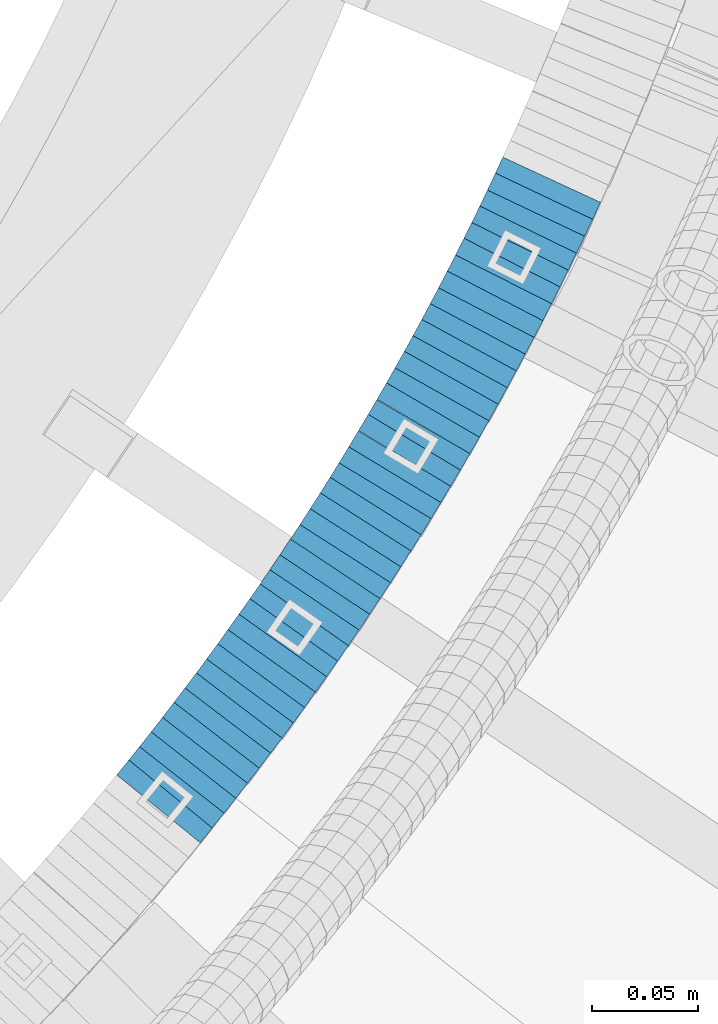
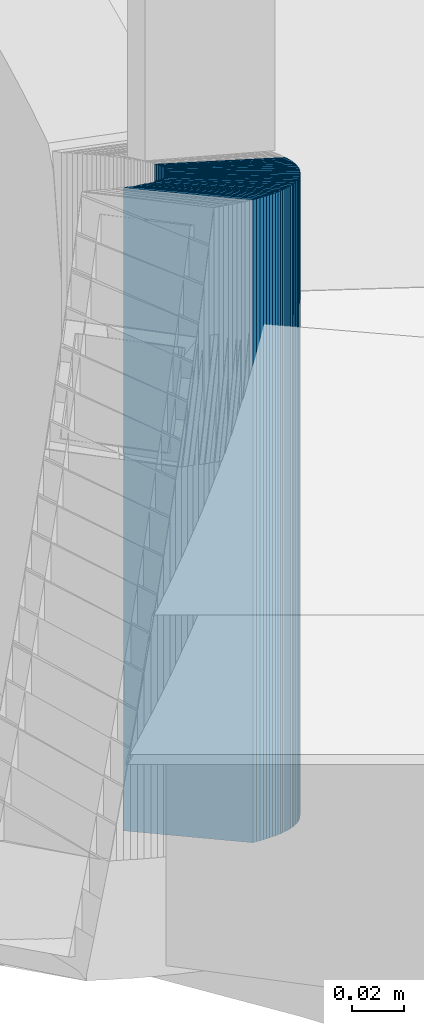
# One storey, part 907 of 975: 40 plates.
"""IFC2X3 building model written with IfcOpenShell, lengths in millimetres."""

from ifc_helpers import new_model, si_unit, frame, origin_with_axes, place, context, subcontext, project, spatial, faceted_brep, material, type_object, element, save


model = new_model("IFC2X3")

# Units and contexts
model_context = context("Model", 3, precision=1e-05, world=origin_with_axes())
body_context = subcontext(model_context, "Body", "Model", "MODEL_VIEW")
ifc_project = project(units=[si_unit("LENGTHUNIT", "METRE", prefix="MILLI"), si_unit("AREAUNIT", "SQUARE_METRE"), si_unit("VOLUMEUNIT", "CUBIC_METRE"), si_unit("MASSUNIT", "GRAM", prefix="KILO"), si_unit("TIMEUNIT", "SECOND"), si_unit("PLANEANGLEUNIT", "RADIAN"), si_unit("SOLIDANGLEUNIT", "STERADIAN"), si_unit("THERMODYNAMICTEMPERATUREUNIT", "DEGREE_CELSIUS"), si_unit("LUMINOUSINTENSITYUNIT", "LUMEN")], contexts=[model_context])

# Site, building, storey
site_placement = place(None, origin_with_axes())
site = spatial("IfcSite", under=ifc_project, at=site_placement, CompositionType="ELEMENT")
building_placement = place(site_placement, origin_with_axes())
building = spatial("IfcBuilding", under=site, at=building_placement, Name="Undefined", CompositionType="ELEMENT")
storey_placement = place(building_placement, origin_with_axes())
storey = spatial("IfcBuildingStorey", under=building, at=storey_placement, Name="Undefined", CompositionType="ELEMENT", Elevation=0.0)

# Plates
ifc_material = material(Name="STEEL/A36")
plate_type = type_object("IfcPlateType", PredefinedType="NOTDEFINED")
plate_1_placement = place(storey_placement, frame((35822.3691600737, 2526.91215876217, 2256.22500005033), z_axis=(-0.631426343123668, -0.775435860151871, 0.0), x_axis=(0.0, 0.0, 1.0)))
element("IfcPlate", 1, at=plate_1_placement, inside=storey, type_object=plate_type, material=ifc_material, Name="WALL", context=body_context, shape_type="Brep", body=[
    faceted_brep([(0.0, -25.3999999999724, -1.81898940354586e-11), (5.69999980926514, -25.3999999999901, 9.02718162541714), (5.69999980926514, 25.3999999999951, 9.02718162535166), (0.0, 25.3999999999869, 1.45519152283669e-11), (310.5, -25.3999999999901, 9.02718162541714), (310.5, 25.3999999999951, 9.02718162535166), (304.799987792969, -25.3999999999724, -1.81898940354586e-11), (304.799987792969, 25.3999999999869, 1.45519152283669e-11)], [[[0, 1, 2, 3]], [[1, 4, 5, 2]], [[4, 6, 7, 5]], [[6, 0, 3, 7]], [[5, 7, 3, 2]], [[6, 4, 1, 0]]]),
])
plate_2_placement = place(storey_placement, frame((35827.831163173, 2533.74118386725, 2250.42500005033), z_axis=(-0.624695048042231, -0.780868809052785, 0.0), x_axis=(0.0, 0.0, 1.0)))
element("IfcPlate", 2, at=plate_2_placement, inside=storey, type_object=plate_type, material=ifc_material, Name="WALL", context=body_context, shape_type="Brep", body=[
    faceted_brep([(0.0, -25.3999999999724, -1.81898940354586e-11), (5.80000019073486, -25.3999999999105, 8.96270084375283), (5.80000019073486, 25.399999999936, 8.96270084385833), (0.0, 25.3999999999869, 1.45519152283669e-11), (310.600006103516, -25.3999999999105, 8.96270084375283), (310.600006103516, 25.399999999936, 8.96270084385833), (304.799987792969, -25.3999999999724, -1.81898940354586e-11), (304.799987792969, 25.3999999999869, 1.45519152283669e-11)], [[[0, 1, 2, 3]], [[1, 4, 5, 2]], [[4, 6, 7, 5]], [[6, 0, 3, 7]], [[5, 7, 3, 2]], [[6, 4, 1, 0]]]),
])
plate_3_placement = place(storey_placement, frame((35833.1927451164, 2540.56659706509, 2244.72500005033), z_axis=(-0.61782155188774, -0.786318338857122, 0.0), x_axis=(0.0, 0.0, 1.0)))
element("IfcPlate", 3, at=plate_3_placement, inside=storey, type_object=plate_type, material=ifc_material, Name="WALL", context=body_context, shape_type="Brep", body=[
    faceted_brep([(0.0, -25.3999999999724, -1.81898940354586e-11), (5.69999980926514, -25.3999999999469, 8.90224647518698), (5.69999980926514, 25.399999999936, 8.90224647526338), (0.0, 25.3999999999869, 1.45519152283669e-11), (310.5, -25.3999999999469, 8.90224647518698), (310.5, 25.399999999936, 8.90224647526338), (304.799987792969, -25.3999999999724, -1.81898940354586e-11), (304.799987792969, 25.3999999999869, 1.45519152283669e-11)], [[[0, 1, 2, 3]], [[1, 4, 5, 2]], [[4, 6, 7, 5]], [[6, 0, 3, 7]], [[5, 7, 3, 2]], [[6, 4, 1, 0]]]),
])
plate_4_placement = place(storey_placement, frame((35838.5852656948, 2547.52883229645, 2239.02500005033), z_axis=(-0.612397742104128, -0.79054981213442, 0.0), x_axis=(0.0, 0.0, 1.0)))
element("IfcPlate", 4, at=plate_4_placement, inside=storey, type_object=plate_type, material=ifc_material, Name="WALL", context=body_context, shape_type="Brep", body=[
    faceted_brep([(0.0, -25.3999999999724, -1.81898940354586e-11), (5.69999980926514, -25.3999999999542, 8.98276138300935), (5.69999980926514, 25.3999999999614, 8.98276138309302), (0.0, 25.3999999999869, 1.45519152283669e-11), (310.5, -25.3999999999542, 8.98276138300935), (310.5, 25.3999999999614, 8.98276138309302), (304.799987792969, -25.3999999999724, -1.81898940354586e-11), (304.799987792969, 25.3999999999869, 1.45519152283669e-11)], [[[0, 1, 2, 3]], [[1, 4, 5, 2]], [[4, 6, 7, 5]], [[6, 0, 3, 7]], [[5, 7, 3, 2]], [[6, 4, 1, 0]]]),
])
plate_5_placement = place(storey_placement, frame((35844.0852656944, 2554.62883229637, 2233.22500005033), z_axis=(-0.612397742104128, -0.79054981213442, 0.0), x_axis=(0.0, 0.0, 1.0)))
element("IfcPlate", 5, at=plate_5_placement, inside=storey, type_object=plate_type, material=ifc_material, Name="WALL", context=body_context, shape_type="Brep", body=[
    faceted_brep([(0.0, -25.3999999999724, -1.81898940354586e-11), (5.80000019073486, -25.3999999999432, 8.98109149925949), (5.80000019073486, 25.3999999999651, 8.98109149937954), (0.0, 25.3999999999869, 1.45519152283669e-11), (310.600006103516, -25.3999999999432, 8.98109149925949), (310.600006103516, 25.3999999999651, 8.98109149937954), (304.799987792969, -25.3999999999724, -1.81898940354586e-11), (304.799987792969, 25.3999999999869, 1.45519152283669e-11)], [[[0, 1, 2, 3]], [[1, 4, 5, 2]], [[4, 6, 7, 5]], [[6, 0, 3, 7]], [[5, 7, 3, 2]], [[6, 4, 1, 0]]]),
])
plate_6_placement = place(storey_placement, frame((35849.3481994944, 2561.5502634159, 2227.52500005033), z_axis=(-0.605367471213059, -0.795946119280134, 0.0), x_axis=(0.0, 0.0, 1.0)))
element("IfcPlate", 6, at=plate_6_placement, inside=storey, type_object=plate_type, material=ifc_material, Name="WALL", context=body_context, shape_type="Brep", body=[
    faceted_brep([(0.0, -25.3999999999724, -1.81898940354586e-11), (5.69999980926514, -25.4000000000269, 8.9196414947728), (5.69999980926514, 25.3999999999796, 8.91964149476189), (0.0, 25.3999999999869, 1.45519152283669e-11), (310.5, -25.4000000000269, 8.9196414947728), (310.5, 25.3999999999796, 8.91964149476189), (304.799987792969, -25.3999999999724, -1.81898940354586e-11), (304.799987792969, 25.3999999999869, 1.45519152283669e-11)], [[[0, 1, 2, 3]], [[1, 4, 5, 2]], [[4, 6, 7, 5]], [[6, 0, 3, 7]], [[5, 7, 3, 2]], [[6, 4, 1, 0]]]),
])
plate_7_placement = place(storey_placement, frame((35854.7481994959, 2568.65026341598, 2221.72500005033), z_axis=(-0.605367471213059, -0.795946119280134, 0.0), x_axis=(0.0, 0.0, 1.0)))
element("IfcPlate", 7, at=plate_7_placement, inside=storey, type_object=plate_type, material=ifc_material, Name="WALL", context=body_context, shape_type="Brep", body=[
    faceted_brep([(0.0, -25.3999999999724, -1.81898940354586e-11), (5.80000019073486, -25.3999999999633, 8.91964149466003), (5.80000019073486, 25.3999999999669, 8.91964149481646), (0.0, 25.3999999999869, 1.45519152283669e-11), (310.600006103516, -25.3999999999633, 8.91964149466003), (310.600006103516, 25.3999999999669, 8.91964149481646), (304.799987792969, -25.3999999999724, -1.81898940354586e-11), (304.799987792969, 25.3999999999869, 1.45519152283669e-11)], [[[0, 1, 2, 3]], [[1, 4, 5, 2]], [[4, 6, 7, 5]], [[6, 0, 3, 7]], [[5, 7, 3, 2]], [[6, 4, 1, 0]]]),
])
plate_8_placement = place(storey_placement, frame((35859.8096740707, 2575.53149232084, 2216.02500005033), z_axis=(-0.592817428097412, -0.80533688413233, 0.0), x_axis=(0.0, 0.0, 1.0)))
element("IfcPlate", 8, at=plate_8_placement, inside=storey, type_object=plate_type, material=ifc_material, Name="WALL", context=body_context, shape_type="Brep", body=[
    faceted_brep([(0.0, -25.3999999999724, -1.81898940354586e-11), (5.69999980926514, -25.4000000000851, 8.94035816198448), (5.69999980926514, 25.4000000000524, 8.94035816188989), (0.0, 25.3999999999869, 1.45519152283669e-11), (310.5, -25.4000000000851, 8.94035816198448), (310.5, 25.4000000000524, 8.94035816188989), (304.799987792969, -25.3999999999724, -1.81898940354586e-11), (304.799987792969, 25.3999999999869, 1.45519152283669e-11)], [[[0, 1, 2, 3]], [[1, 4, 5, 2]], [[4, 6, 7, 5]], [[6, 0, 3, 7]], [[5, 7, 3, 2]], [[6, 4, 1, 0]]]),
])
plate_9_placement = place(storey_placement, frame((35865.1096740726, 2582.73149232089, 2210.22500005033), z_axis=(-0.592817428097412, -0.80533688413233, 0.0), x_axis=(0.0, 0.0, 1.0)))
element("IfcPlate", 9, at=plate_9_placement, inside=storey, type_object=plate_type, material=ifc_material, Name="WALL", context=body_context, shape_type="Brep", body=[
    faceted_brep([(0.0, -25.3999999999724, -1.81898940354586e-11), (5.80000019073486, -25.4000000000087, 8.9375610351708), (5.80000019073486, 25.400000000016, 8.93756103512715), (0.0, 25.3999999999869, 1.45519152283669e-11), (310.600006103516, -25.4000000000087, 8.9375610351708), (310.600006103516, 25.400000000016, 8.93756103512715), (304.799987792969, -25.3999999999724, -1.81898940354586e-11), (304.799987792969, 25.3999999999869, 1.45519152283669e-11)], [[[0, 1, 2, 3]], [[1, 4, 5, 2]], [[4, 6, 7, 5]], [[6, 0, 3, 7]], [[5, 7, 3, 2]], [[6, 4, 1, 0]]]),
])
for number, where, z_axis, x_axis, name in (
    (10, (35870.0772697226, 2589.71055955485, 2204.52500005033), (-0.580182279825393, -0.81448666175488, 0.0), (0.0, 0.0, 1.0), "WALL"),
    (11, (35875.2772697243, 2597.0105595549, 2198.82500005033), (-0.580182279825393, -0.81448666175488, 0.0), (0.0, 0.0, 1.0), "WALL"),
):
    element("IfcPlate", number, at=place(storey_placement, frame(where, z_axis=z_axis, x_axis=x_axis)), inside=storey, type_object=plate_type, material=ifc_material, Name=name, context=body_context, shape_type="Brep", body=[
        faceted_brep([(0.0, -25.3999999999724, -1.81898940354586e-11), (5.69999980926514, -25.3999999999105, 8.96270084374919), (5.69999980926514, 25.399999999936, 8.96270084385469), (0.0, 25.3999999999869, 1.45519152283669e-11), (310.5, -25.3999999999105, 8.96270084374919), (310.5, 25.399999999936, 8.96270084385469), (304.799987792969, -25.3999999999724, -1.81898940354586e-11), (304.799987792969, 25.3999999999869, 1.45519152283669e-11)], [[[0, 1, 2, 3]], [[1, 4, 5, 2]], [[4, 6, 7, 5]], [[6, 0, 3, 7]], [[5, 7, 3, 2]], [[6, 4, 1, 0]]]),
    ])
plate_10_placement = place(storey_placement, frame((35880.4772697261, 2604.31055955494, 2193.02500005033), z_axis=(-0.580182279825393, -0.81448666175488, 0.0), x_axis=(0.0, 0.0, 1.0)))
element("IfcPlate", 12, at=plate_10_placement, inside=storey, type_object=plate_type, material=ifc_material, Name="WALL", context=body_context, shape_type="Brep", body=[
    faceted_brep([(0.0, -25.3999999999724, -1.81898940354586e-11), (5.80000019073486, -25.3999999999105, 8.96270084375283), (5.80000019073486, 25.399999999936, 8.96270084385833), (0.0, 25.3999999999869, 1.45519152283669e-11), (310.600006103516, -25.3999999999105, 8.96270084375283), (310.600006103516, 25.399999999936, 8.96270084385833), (304.799987792969, -25.3999999999724, -1.81898940354586e-11), (304.799987792969, 25.3999999999869, 1.45519152283669e-11)], [[[0, 1, 2, 3]], [[1, 4, 5, 2]], [[4, 6, 7, 5]], [[6, 0, 3, 7]], [[5, 7, 3, 2]], [[6, 4, 1, 0]]]),
])
plate_11_placement = place(storey_placement, frame((35885.4433488354, 2611.42072399488, 2187.32500005033), z_axis=(-0.572708438875059, -0.819759137821161, 0.0), x_axis=(0.0, 0.0, 1.0)))
element("IfcPlate", 13, at=plate_11_placement, inside=storey, type_object=plate_type, material=ifc_material, Name="WALL", context=body_context, shape_type="Brep", body=[
    faceted_brep([(0.0, -25.3999999999724, -1.81898940354586e-11), (5.69999980926514, -25.4000000000269, 8.91066741947361), (5.69999980926514, 25.4000000000269, 8.91066741941904), (0.0, 25.3999999999869, 1.45519152283669e-11), (310.5, -25.4000000000269, 8.91066741947361), (310.5, 25.4000000000269, 8.91066741941904), (304.799987792969, -25.3999999999724, -1.81898940354586e-11), (304.799987792969, 25.3999999999869, 1.45519152283669e-11)], [[[0, 1, 2, 3]], [[1, 4, 5, 2]], [[4, 6, 7, 5]], [[6, 0, 3, 7]], [[5, 7, 3, 2]], [[6, 4, 1, 0]]]),
])
for number, where, z_axis, x_axis, name in (
    (14, (35890.2190711247, 2618.49430788544, 2181.62500005033), (-0.559857410943981, -0.8285889689171, 0.0), (0.0, 0.0, 1.0), "WALL"),
    (15, (35895.2190711239, 2625.89430788548, 2175.92500005033), (-0.559857410943981, -0.8285889689171, 0.0), (0.0, 0.0, 1.0), "WALL"),
):
    element("IfcPlate", number, at=place(storey_placement, frame(where, z_axis=z_axis, x_axis=x_axis)), inside=storey, type_object=plate_type, material=ifc_material, Name=name, context=body_context, shape_type="Brep", body=[
        faceted_brep([(0.0, -25.3999999999724, -1.81898940354586e-11), (5.69999980926514, -25.3999999999542, 8.93084526058738), (5.69999980926514, 25.3999999999178, 8.93084526067832), (0.0, 25.3999999999869, 1.45519152283669e-11), (310.5, -25.3999999999542, 8.93084526058738), (310.5, 25.3999999999178, 8.93084526067832), (304.799987792969, -25.3999999999724, -1.81898940354586e-11), (304.799987792969, 25.3999999999869, 1.45519152283669e-11)], [[[0, 1, 2, 3]], [[1, 4, 5, 2]], [[4, 6, 7, 5]], [[6, 0, 3, 7]], [[5, 7, 3, 2]], [[6, 4, 1, 0]]]),
    ])
plate_12_placement = place(storey_placement, frame((35899.9872275383, 2633.09720216495, 2170.12500005033), z_axis=(-0.552097343208436, -0.833779661314779, 0.0), x_axis=(0.0, 0.0, 1.0)))
element("IfcPlate", 16, at=plate_12_placement, inside=storey, type_object=plate_type, material=ifc_material, Name="WALL", context=body_context, shape_type="Brep", body=[
    faceted_brep([(0.0, -25.3999999999724, -1.81898940354586e-11), (5.80000019073486, -25.3999999999724, 8.87524604794817), (5.80000019073486, 25.3999999999651, 8.87524604802456), (0.0, 25.3999999999869, 1.45519152283669e-11), (310.600006103516, -25.3999999999724, 8.87524604794817), (310.600006103516, 25.3999999999651, 8.87524604802456), (304.799987792969, -25.3999999999724, -1.81898940354586e-11), (304.799987792969, 25.3999999999869, 1.45519152283669e-11)], [[[0, 1, 2, 3]], [[1, 4, 5, 2]], [[4, 6, 7, 5]], [[6, 0, 3, 7]], [[5, 7, 3, 2]], [[6, 4, 1, 0]]]),
])
plate_13_placement = place(storey_placement, frame((35905.0311534596, 2640.66331463167, 2164.42500005033), z_axis=(-0.554700196225226, -0.832050294337846, 0.0), x_axis=(0.0, 0.0, 1.0)))
element("IfcPlate", 17, at=plate_13_placement, inside=storey, type_object=plate_type, material=ifc_material, Name="WALL", context=body_context, shape_type="Brep", body=[
    faceted_brep([(0.0, -25.3999999999724, -1.81898940354586e-11), (5.69999980926514, -25.4000000000233, 9.01387786867781), (5.69999980926514, 25.400000000016, 9.01387786863415), (0.0, 25.3999999999869, 1.45519152283669e-11), (310.5, -25.4000000000233, 9.01387786867781), (310.5, 25.400000000016, 9.01387786863415), (304.799987792969, -25.3999999999724, -1.81898940354586e-11), (304.799987792969, 25.3999999999869, 1.45519152283669e-11)], [[[0, 1, 2, 3]], [[1, 4, 5, 2]], [[4, 6, 7, 5]], [[6, 0, 3, 7]], [[5, 7, 3, 2]], [[6, 4, 1, 0]]]),
])
plate_14_placement = place(storey_placement, frame((35909.5715373509, 2647.7658935251, 2158.72500005033), z_axis=(-0.539053695969341, -0.842271400952088, 0.0), x_axis=(0.0, 0.0, 1.0)))
element("IfcPlate", 18, at=plate_14_placement, inside=storey, type_object=plate_type, material=ifc_material, Name="WALL", context=body_context, shape_type="Brep", body=[
    faceted_brep([(0.0, -25.3999999999724, -1.81898940354586e-11), (5.69999980926514, -25.3999999999469, 8.90224647518698), (5.69999980926514, 25.399999999936, 8.90224647526338), (0.0, 25.3999999999869, 1.45519152283669e-11), (310.5, -25.3999999999469, 8.90224647518698), (310.5, 25.399999999936, 8.90224647526338), (304.799987792969, -25.3999999999724, -1.81898940354586e-11), (304.799987792969, 25.3999999999869, 1.45519152283669e-11)], [[[0, 1, 2, 3]], [[1, 4, 5, 2]], [[4, 6, 7, 5]], [[6, 0, 3, 7]], [[5, 7, 3, 2]], [[6, 4, 1, 0]]]),
])
plate_15_placement = place(storey_placement, frame((35914.3715373504, 2655.26589352503, 2152.92500005033), z_axis=(-0.539053695969341, -0.842271400952088, 0.0), x_axis=(0.0, 0.0, 1.0)))
element("IfcPlate", 19, at=plate_15_placement, inside=storey, type_object=plate_type, material=ifc_material, Name="WALL", context=body_context, shape_type="Brep", body=[
    faceted_brep([(0.0, -25.3999999999724, -1.81898940354586e-11), (5.80000019073486, -25.3999999999687, 8.90449333185097), (5.80000019073486, 25.3999999999833, 8.90449333192373), (0.0, 25.3999999999869, 1.45519152283669e-11), (310.600006103516, -25.3999999999687, 8.90449333185097), (310.600006103516, 25.3999999999833, 8.90449333192373), (304.799987792969, -25.3999999999724, -1.81898940354586e-11), (304.799987792969, 25.3999999999869, 1.45519152283669e-11)], [[[0, 1, 2, 3]], [[1, 4, 5, 2]], [[4, 6, 7, 5]], [[6, 0, 3, 7]], [[5, 7, 3, 2]], [[6, 4, 1, 0]]]),
])
plate_16_placement = place(storey_placement, frame((35919.089812793, 2662.73735162201, 2147.22500005033), z_axis=(-0.533992991124615, -0.845488903197308, 0.0), x_axis=(0.0, 0.0, 1.0)))
element("IfcPlate", 20, at=plate_16_placement, inside=storey, type_object=plate_type, material=ifc_material, Name="WALL", context=body_context, shape_type="Brep", body=[
    faceted_brep([(0.0, -25.3999999999724, -1.81898940354586e-11), (5.69999980926514, -25.4000000000196, 8.98721313477654), (5.69999980926514, 25.4000000000669, 8.98721313470742), (0.0, 25.3999999999869, 1.45519152283669e-11), (310.5, -25.4000000000196, 8.98721313477654), (310.5, 25.4000000000669, 8.98721313470742), (304.799987792969, -25.3999999999724, -1.81898940354586e-11), (304.799987792969, 25.3999999999869, 1.45519152283669e-11)], [[[0, 1, 2, 3]], [[1, 4, 5, 2]], [[4, 6, 7, 5]], [[6, 0, 3, 7]], [[5, 7, 3, 2]], [[6, 4, 1, 0]]]),
])
plate_17_placement = place(storey_placement, frame((35923.6624406916, 2670.1335499162, 2141.52500005033), z_axis=(-0.525969301917948, -0.850503552867328, 0.0), x_axis=(0.0, 0.0, 1.0)))
element("IfcPlate", 21, at=plate_17_placement, inside=storey, type_object=plate_type, material=ifc_material, Name="WALL", context=body_context, shape_type="Brep", body=[
    faceted_brep([(0.0, -25.3999999999724, -1.81898940354586e-11), (5.69999980926514, -25.4000000000851, 8.94035816198448), (5.69999980926514, 25.4000000000524, 8.94035816188989), (0.0, 25.3999999999869, 1.45519152283669e-11), (310.5, -25.4000000000851, 8.94035816198448), (310.5, 25.4000000000524, 8.94035816188989), (304.799987792969, -25.3999999999724, -1.81898940354586e-11), (304.799987792969, 25.3999999999869, 1.45519152283669e-11)], [[[0, 1, 2, 3]], [[1, 4, 5, 2]], [[4, 6, 7, 5]], [[6, 0, 3, 7]], [[5, 7, 3, 2]], [[6, 4, 1, 0]]]),
])
plate_18_placement = place(storey_placement, frame((35928.135528922, 2677.5261176971, 2135.72500005033), z_axis=(-0.517802679116874, -0.855500079193093, 0.0), x_axis=(0.0, 0.0, 1.0)))
element("IfcPlate", 22, at=plate_18_placement, inside=storey, type_object=plate_type, material=ifc_material, Name="WALL", context=body_context, shape_type="Brep", body=[
    faceted_brep([(0.0, -25.3999999999724, -1.81898940354586e-11), (5.80000019073486, -25.3999999999724, 8.87524604794817), (5.80000019073486, 25.3999999999651, 8.87524604802456), (0.0, 25.3999999999869, 1.45519152283669e-11), (310.600006103516, -25.3999999999724, 8.87524604794817), (310.600006103516, 25.3999999999651, 8.87524604802456), (304.799987792969, -25.3999999999724, -1.81898940354586e-11), (304.799987792969, 25.3999999999869, 1.45519152283669e-11)], [[[0, 1, 2, 3]], [[1, 4, 5, 2]], [[4, 6, 7, 5]], [[6, 0, 3, 7]], [[5, 7, 3, 2]], [[6, 4, 1, 0]]]),
])
plate_19_placement = place(storey_placement, frame((35932.6599634946, 2685.1004530487, 2130.02500005033), z_axis=(-0.512855252011235, -0.858475096018803, 0.0), x_axis=(0.0, 0.0, 1.0)))
element("IfcPlate", 23, at=plate_19_placement, inside=storey, type_object=plate_type, material=ifc_material, Name="WALL", context=body_context, shape_type="Brep", body=[
    faceted_brep([(0.0, -25.3999999999724, -1.81898940354586e-11), (5.69999980926514, -25.4000000000124, 8.96939277650017), (5.69999980926514, 25.3999999999869, 8.96939277651836), (0.0, 25.3999999999869, 1.45519152283669e-11), (310.5, -25.4000000000124, 8.96939277650017), (310.5, 25.3999999999869, 8.96939277651836), (304.799987792969, -25.3999999999724, -1.81898940354586e-11), (304.799987792969, 25.3999999999869, 1.45519152283669e-11)], [[[0, 1, 2, 3]], [[1, 4, 5, 2]], [[4, 6, 7, 5]], [[6, 0, 3, 7]], [[5, 7, 3, 2]], [[6, 4, 1, 0]]]),
])
plate_20_placement = place(storey_placement, frame((35937.3355289211, 2692.82611769727, 2124.32500005033), z_axis=(-0.517802679116874, -0.855500079193093, 0.0), x_axis=(0.0, 0.0, 1.0)))
element("IfcPlate", 24, at=plate_20_placement, inside=storey, type_object=plate_type, material=ifc_material, Name="WALL", context=body_context, shape_type="Brep", body=[
    faceted_brep([(0.0, -25.3999999999724, -1.81898940354586e-11), (5.69999980926514, -25.4000000000306, 8.88144111634756), (5.69999980926514, 25.4000000000378, 8.88144111629663), (0.0, 25.3999999999869, 1.45519152283669e-11), (310.5, -25.4000000000306, 8.88144111634756), (310.5, 25.4000000000378, 8.88144111629663), (304.799987792969, -25.3999999999724, -1.81898940354586e-11), (304.799987792969, 25.3999999999869, 1.45519152283669e-11)], [[[0, 1, 2, 3]], [[1, 4, 5, 2]], [[4, 6, 7, 5]], [[6, 0, 3, 7]], [[5, 7, 3, 2]], [[6, 4, 1, 0]]]),
])
plate_21_placement = place(storey_placement, frame((35941.564117042, 2700.16687995742, 2118.62500005033), z_axis=(-0.499722453143295, -0.866185586248378, 0.0), x_axis=(0.0, 0.0, 1.0)))
element("IfcPlate", 25, at=plate_21_placement, inside=storey, type_object=plate_type, material=ifc_material, Name="WALL", context=body_context, shape_type="Brep", body=[
    faceted_brep([(0.0, -25.3999999999724, -1.81898940354586e-11), (5.69999980926514, -25.3999999999978, 9.00277709959482), (5.69999980926514, 25.3999999999651, 9.00277709966031), (0.0, 25.3999999999869, 1.45519152283669e-11), (310.5, -25.3999999999978, 9.00277709959482), (310.5, 25.3999999999651, 9.00277709966031), (304.799987792969, -25.3999999999724, -1.81898940354586e-11), (304.799987792969, 25.3999999999869, 1.45519152283669e-11)], [[[0, 1, 2, 3]], [[1, 4, 5, 2]], [[4, 6, 7, 5]], [[6, 0, 3, 7]], [[5, 7, 3, 2]], [[6, 4, 1, 0]]]),
])
plate_22_placement = place(storey_placement, frame((35946.1355835503, 2707.98995733366, 2112.82500005033), z_axis=(-0.504568019130195, -0.863371944222785, 0.0), x_axis=(0.0, 0.0, 1.0)))
element("IfcPlate", 26, at=plate_22_placement, inside=storey, type_object=plate_type, material=ifc_material, Name="WALL", context=body_context, shape_type="Brep", body=[
    faceted_brep([(0.0, -25.3999999999724, -1.81898940354586e-11), (5.80000019073486, -25.3999999999633, 8.91964149466003), (5.80000019073486, 25.3999999999669, 8.91964149481646), (0.0, 25.3999999999869, 1.45519152283669e-11), (310.600006103516, -25.3999999999633, 8.91964149466003), (310.600006103516, 25.3999999999669, 8.91964149481646), (304.799987792969, -25.3999999999724, -1.81898940354586e-11), (304.799987792969, 25.3999999999869, 1.45519152283669e-11)], [[[0, 1, 2, 3]], [[1, 4, 5, 2]], [[4, 6, 7, 5]], [[6, 0, 3, 7]], [[5, 7, 3, 2]], [[6, 4, 1, 0]]]),
])
for number, where, z_axis, x_axis, name in (
    (27, (35950.3423778513, 2715.45348779431, 2107.12500005033), (-0.491321186873553, -0.870978467775847, 0.0), (0.0, 0.0, 1.0), "WALL"),
    (28, (35954.7423778505, 2723.25348779429, 2101.42500005033), (-0.491321186873553, -0.870978467775847, 0.0), (0.0, 0.0, 1.0), "WALL"),
):
    element("IfcPlate", number, at=place(storey_placement, frame(where, z_axis=z_axis, x_axis=x_axis)), inside=storey, type_object=plate_type, material=ifc_material, Name=name, context=body_context, shape_type="Brep", body=[
        faceted_brep([(0.0, -25.3999999999724, -1.81898940354586e-11), (5.69999980926514, -25.3999999999105, 8.96270084374919), (5.69999980926514, 25.399999999936, 8.96270084385469), (0.0, 25.3999999999869, 1.45519152283669e-11), (310.5, -25.3999999999105, 8.96270084374919), (310.5, 25.399999999936, 8.96270084385469), (304.799987792969, -25.3999999999724, -1.81898940354586e-11), (304.799987792969, 25.3999999999869, 1.45519152283669e-11)], [[[0, 1, 2, 3]], [[1, 4, 5, 2]], [[4, 6, 7, 5]], [[6, 0, 3, 7]], [[5, 7, 3, 2]], [[6, 4, 1, 0]]]),
    ])
plate_23_placement = place(storey_placement, frame((35958.9213996553, 2730.83655457455, 2095.62500005033), z_axis=(-0.482780508932905, -0.875741388878295, 0.0), x_axis=(0.0, 0.0, 1.0)))
element("IfcPlate", 29, at=plate_23_placement, inside=storey, type_object=plate_type, material=ifc_material, Name="WALL", context=body_context, shape_type="Brep", body=[
    faceted_brep([(0.0, -25.3999999999724, -1.81898940354586e-11), (5.80000019073486, -25.3999999999796, 8.91403388975959), (5.80000019073486, 25.3999999999432, 8.91403388980689), (0.0, 25.3999999999869, 1.45519152283669e-11), (310.600006103515, -25.3999999999796, 8.91403388975959), (310.600006103515, 25.3999999999432, 8.91403388980689), (304.799987792969, -25.3999999999724, -1.81898940354586e-11), (304.799987792969, 25.3999999999869, 1.45519152283669e-11)], [[[0, 1, 2, 3]], [[1, 4, 5, 2]], [[4, 6, 7, 5]], [[6, 0, 3, 7]], [[5, 7, 3, 2]], [[6, 4, 1, 0]]]),
])
plate_24_placement = place(storey_placement, frame((35963.1558999372, 2738.61698323783, 2089.92500005033), z_axis=(-0.478072975651703, -0.878320118152559, -2.40087956626667e-10), x_axis=(0.0, 0.0, 1.0)))
element("IfcPlate", 30, at=plate_24_placement, inside=storey, type_object=plate_type, material=ifc_material, Name="WALL", context=body_context, shape_type="Brep", body=[
    faceted_brep([(0.0, -25.3999999999724, -1.81898940354586e-11), (5.69999980926514, -25.4000000000196, 8.98721313477654), (5.69999980926514, 25.4000000000669, 8.98721313470742), (0.0, 25.3999999999869, 1.45519152283669e-11), (310.5, -25.4000000000196, 8.98721313477654), (310.5, 25.4000000000669, 8.98721313470742), (304.799987792969, -25.3999999999724, -1.81898940354586e-11), (304.799987792969, 25.3999999999869, 1.45519152283669e-11)], [[[0, 1, 2, 3]], [[1, 4, 5, 2]], [[4, 6, 7, 5]], [[6, 0, 3, 7]], [[5, 7, 3, 2]], [[6, 4, 1, 0]]]),
])
plate_25_placement = place(storey_placement, frame((35967.2377683999, 2746.29739073653, 2084.12500005033), z_axis=(-0.469427601925258, -0.882970965859411, 0.0), x_axis=(0.0, 0.0, 1.0)))
element("IfcPlate", 31, at=plate_25_placement, inside=storey, type_object=plate_type, material=ifc_material, Name="WALL", context=body_context, shape_type="Brep", body=[
    faceted_brep([(0.0, -25.3999999999724, -1.81898940354586e-11), (5.80000019073486, -25.3999999999942, 8.94930171964734), (5.80000019073486, 25.4000000000015, 8.94930171966917), (0.0, 25.3999999999869, 1.45519152283669e-11), (310.600006103516, -25.3999999999942, 8.94930171964734), (310.600006103516, 25.4000000000015, 8.94930171966917), (304.799987792969, -25.3999999999724, -1.81898940354586e-11), (304.799987792969, 25.3999999999869, 1.45519152283669e-11)], [[[0, 1, 2, 3]], [[1, 4, 5, 2]], [[4, 6, 7, 5]], [[6, 0, 3, 7]], [[5, 7, 3, 2]], [[6, 4, 1, 0]]]),
])
plate_26_placement = place(storey_placement, frame((35971.4377683989, 2754.19739073659, 2078.42500005033), z_axis=(-0.469427601925258, -0.882970965859411, 0.0), x_axis=(0.0, 0.0, 1.0)))
element("IfcPlate", 32, at=plate_26_placement, inside=storey, type_object=plate_type, material=ifc_material, Name="WALL", context=body_context, shape_type="Brep", body=[
    faceted_brep([(0.0, -25.3999999999724, -1.81898940354586e-11), (5.69999980926514, -25.3999999999869, 8.94930171964734), (5.69999980926514, 25.4000000000051, 8.94930171966917), (0.0, 25.3999999999869, 1.45519152283669e-11), (310.5, -25.3999999999869, 8.94930171964734), (310.5, 25.4000000000051, 8.94930171966917), (304.799987792969, -25.3999999999724, -1.81898940354586e-11), (304.799987792969, 25.3999999999869, 1.45519152283669e-11)], [[[0, 1, 2, 3]], [[1, 4, 5, 2]], [[4, 6, 7, 5]], [[6, 0, 3, 7]], [[5, 7, 3, 2]], [[6, 4, 1, 0]]]),
])
plate_27_placement = place(storey_placement, frame((35975.4205865667, 2761.87431470298, 2072.62500005033), z_axis=(-0.460645080913193, -0.887584423832729, 0.0), x_axis=(0.0, 0.0, 1.0)))
element("IfcPlate", 33, at=plate_27_placement, inside=storey, type_object=plate_type, material=ifc_material, Name="WALL", context=body_context, shape_type="Brep", body=[
    faceted_brep([(0.0, -25.3999999999724, -1.81898940354586e-11), (5.80000019073486, -25.3999999999687, 8.90449333185097), (5.80000019073486, 25.3999999999833, 8.90449333192373), (0.0, 25.3999999999869, 1.45519152283669e-11), (310.600006103516, -25.3999999999687, 8.90449333185097), (310.600006103516, 25.3999999999833, 8.90449333192373), (304.799987792969, -25.3999999999724, -1.81898940354586e-11), (304.799987792969, 25.3999999999869, 1.45519152283669e-11)], [[[0, 1, 2, 3]], [[1, 4, 5, 2]], [[4, 6, 7, 5]], [[6, 0, 3, 7]], [[5, 7, 3, 2]], [[6, 4, 1, 0]]]),
])
plate_28_placement = place(storey_placement, frame((35979.4609263662, 2769.75863573415, 2066.92500005033), z_axis=(-0.4560907908015, -0.889933250612686, 0.0), x_axis=(0.0, 0.0, 1.0)))
element("IfcPlate", 34, at=plate_28_placement, inside=storey, type_object=plate_type, material=ifc_material, Name="WALL", context=body_context, shape_type="Brep", body=[
    faceted_brep([(0.0, -25.3999999999724, -1.81898940354586e-11), (5.69999980926514, -25.4000000000196, 8.98721313477654), (5.69999980926514, 25.4000000000669, 8.98721313470742), (0.0, 25.3999999999869, 1.45519152283669e-11), (310.5, -25.4000000000196, 8.98721313477654), (310.5, 25.4000000000669, 8.98721313470742), (304.799987792969, -25.3999999999724, -1.81898940354586e-11), (304.799987792969, 25.3999999999869, 1.45519152283669e-11)], [[[0, 1, 2, 3]], [[1, 4, 5, 2]], [[4, 6, 7, 5]], [[6, 0, 3, 7]], [[5, 7, 3, 2]], [[6, 4, 1, 0]]]),
])
plate_29_placement = place(storey_placement, frame((35983.4044391111, 2777.54774828349, 2061.22500005033), z_axis=(-0.451725143138006, -0.892157158272548, 0.0), x_axis=(0.0, 0.0, 1.0)))
element("IfcPlate", 35, at=plate_29_placement, inside=storey, type_object=plate_type, material=ifc_material, Name="WALL", context=body_context, shape_type="Brep", body=[
    faceted_brep([(0.0, -25.3999999999724, -1.81898940354586e-11), (5.69999980926514, -25.4000000000015, 8.84816360473997), (5.69999980926514, 25.4000000000487, 8.8481636046854), (0.0, 25.3999999999869, 1.45519152283669e-11), (310.5, -25.4000000000015, 8.84816360473997), (310.5, 25.4000000000487, 8.8481636046854), (304.799987792969, -25.3999999999724, -1.81898940354586e-11), (304.799987792969, 25.3999999999869, 1.45519152283669e-11)], [[[0, 1, 2, 3]], [[1, 4, 5, 2]], [[4, 6, 7, 5]], [[6, 0, 3, 7]], [[5, 7, 3, 2]], [[6, 4, 1, 0]]]),
])
plate_30_placement = place(storey_placement, frame((35987.1894126737, 2785.21768803614, 2055.62500005033), z_axis=(-0.442667653085751, -0.896685758173706, 0.0), x_axis=(0.0, 0.0, 1.0)))
element("IfcPlate", 36, at=plate_30_placement, inside=storey, type_object=plate_type, material=ifc_material, Name="WALL", context=body_context, shape_type="Brep", body=[
    faceted_brep([(0.0, -25.3999999999724, -1.81898940354586e-11), (5.59999990463257, -25.4000000000597, 8.81022167202173), (5.59999990463257, 25.400000000056, 8.81022167208357), (0.0, 25.3999999999869, 1.45519152283669e-11), (310.399993896484, -25.4000000000597, 8.81022167202173), (310.399993896484, 25.400000000056, 8.81022167208357), (304.799987792969, -25.3999999999724, -1.81898940354586e-11), (304.799987792969, 25.3999999999869, 1.45519152283669e-11)], [[[0, 1, 2, 3]], [[1, 4, 5, 2]], [[4, 6, 7, 5]], [[6, 0, 3, 7]], [[5, 7, 3, 2]], [[6, 4, 1, 0]]]),
])
plate_31_placement = place(storey_placement, frame((35991.0337702577, 2793.10426672753, 2049.92500005033), z_axis=(-0.438202247231412, -0.898876404474686, 0.0), x_axis=(0.0, 0.0, 1.0)))
element("IfcPlate", 37, at=plate_31_placement, inside=storey, type_object=plate_type, material=ifc_material, Name="WALL", context=body_context, shape_type="Brep", body=[
    faceted_brep([(0.0, -25.3999999999724, -1.81898940354586e-11), (5.69999980926514, -25.3999999999469, 8.90224647518698), (5.69999980926514, 25.399999999936, 8.90224647526338), (0.0, 25.3999999999869, 1.45519152283669e-11), (310.5, -25.3999999999469, 8.90224647518698), (310.5, 25.399999999936, 8.90224647526338), (304.799987792969, -25.3999999999724, -1.81898940354586e-11), (304.799987792969, 25.3999999999869, 1.45519152283669e-11)], [[[0, 1, 2, 3]], [[1, 4, 5, 2]], [[4, 6, 7, 5]], [[6, 0, 3, 7]], [[5, 7, 3, 2]], [[6, 4, 1, 0]]]),
])
for number, where, z_axis, x_axis, name in (
    (38, (35994.721982327, 2800.8719727504, 2044.22500005033), (-0.429056815057839, -0.903277504121753, 0.0), (0.0, 0.0, 1.0), "WALL"),
    (39, (35998.5219823275, 2808.87197275042, 2038.52500005033), (-0.429056815057839, -0.903277504121753, 0.0), (0.0, 0.0, 1.0), "WALL"),
):
    element("IfcPlate", number, at=place(storey_placement, frame(where, z_axis=z_axis, x_axis=x_axis)), inside=storey, type_object=plate_type, material=ifc_material, Name=name, context=body_context, shape_type="Brep", body=[
        faceted_brep([(0.0, -25.3999999999724, -1.81898940354586e-11), (5.69999980926514, -25.4000000000378, 8.86171531681612), (5.69999980926514, 25.3999999999978, 8.86171531676882), (0.0, 25.3999999999869, 1.45519152283669e-11), (310.5, -25.4000000000378, 8.86171531681612), (310.5, 25.3999999999978, 8.86171531676882), (304.799987792969, -25.3999999999724, -1.81898940354586e-11), (304.799987792969, 25.3999999999869, 1.45519152283669e-11)], [[[0, 1, 2, 3]], [[1, 4, 5, 2]], [[4, 6, 7, 5]], [[6, 0, 3, 7]], [[5, 7, 3, 2]], [[6, 4, 1, 0]]]),
    ])
plate_32_placement = place(storey_placement, frame((36002.1115040924, 2816.63627829979, 2032.82500005033), z_axis=(-0.41977750597943, -0.907627040955529, 0.0), x_axis=(0.0, 0.0, 1.0)))
element("IfcPlate", 40, at=plate_32_placement, inside=storey, type_object=plate_type, material=ifc_material, Name="WALL", context=body_context, shape_type="Brep", body=[
    faceted_brep([(0.0, -25.3999999999724, -1.81898940354586e-11), (5.69999980926514, -25.4000000000233, 8.81419277189707), (5.69999980926514, 25.4000000000306, 8.81419277192981), (0.0, 25.3999999999869, 1.45519152283669e-11), (310.5, -25.4000000000233, 8.81419277189707), (310.5, 25.4000000000306, 8.81419277192981), (304.799987792969, -25.3999999999724, -1.81898940354586e-11), (304.799987792969, 25.3999999999869, 1.45519152283669e-11)], [[[0, 1, 2, 3]], [[1, 4, 5, 2]], [[4, 6, 7, 5]], [[6, 0, 3, 7]], [[5, 7, 3, 2]], [[6, 4, 1, 0]]]),
])

save(model, "model.ifc")
